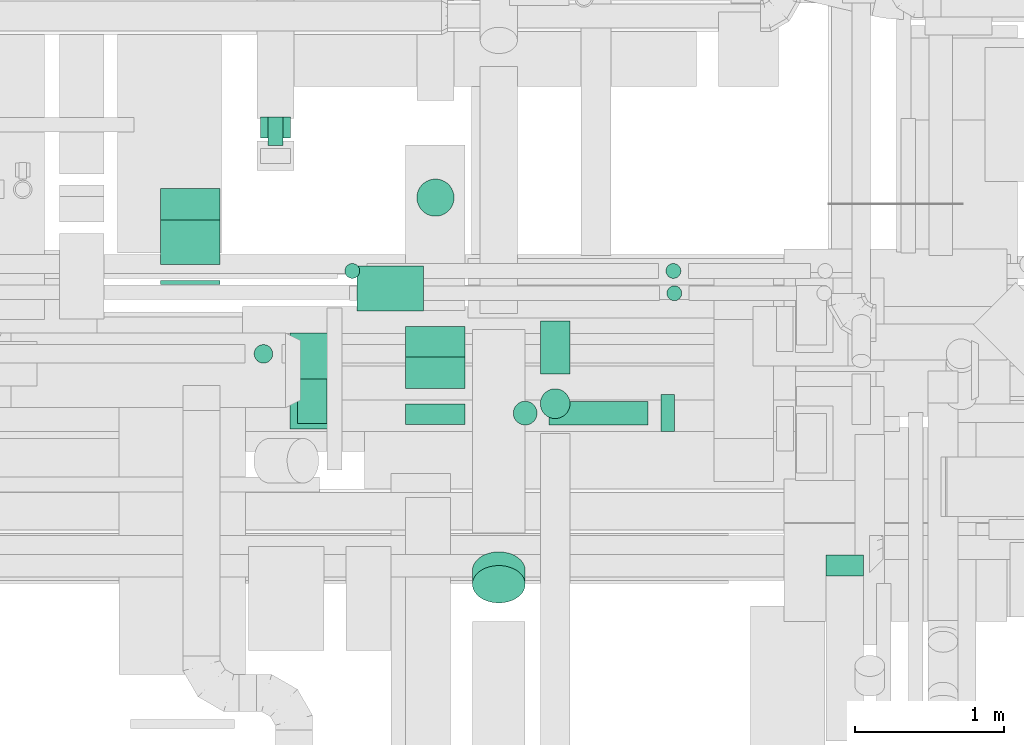
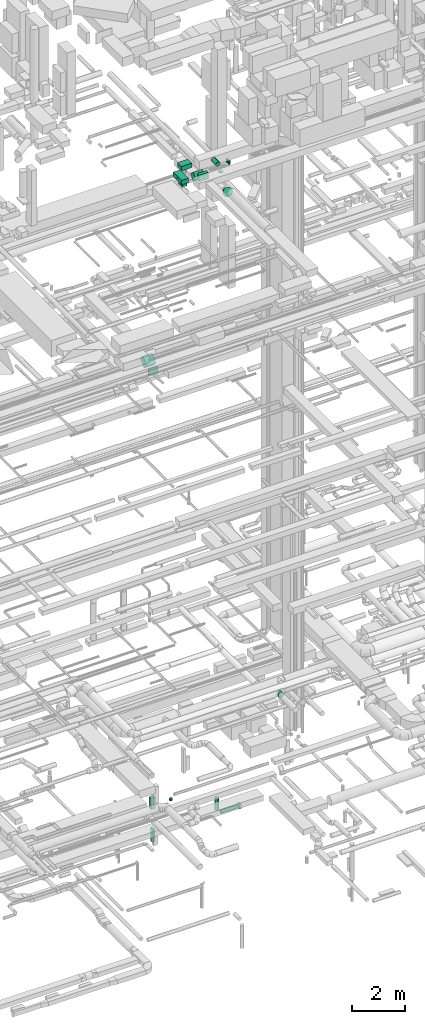
# One storey, part 170 of 337: 20 flow segments, 1 flow fitting.
"""IFC2X3 building model written with IfcOpenShell, lengths in millimetres."""

from ifc_helpers import new_model, entity, si_unit, converted_unit, derived_unit, direction, frame, frame_2d, origin, origin_2d_with_axis, place, context, subcontext, project, spatial, rectangle, circle, extrude, faceted_brep, source, transform, mapped, material, type_object, type_shapes, element, save


model = new_model("IFC2X3")

# Units and contexts
model_context = context("Model", 3, precision=0.01, world=origin(), true_north=direction((6.12303176911189e-17, 1.0)))
body_context = subcontext(model_context, "Body", "Model", "MODEL_VIEW")
ifc_project = project(units=[si_unit("LENGTHUNIT", "METRE", prefix="MILLI"), si_unit("AREAUNIT", "SQUARE_METRE"), si_unit("VOLUMEUNIT", "CUBIC_METRE"), converted_unit("PLANEANGLEUNIT", "DEGREE", entity("IfcRatioMeasure", 0.0174532925199433), si_unit("PLANEANGLEUNIT", "RADIAN"), dimensions=[0, 0, 0, 0, 0, 0, 0]), si_unit("MASSUNIT", "GRAM", prefix="KILO"), derived_unit("MASSDENSITYUNIT", [(si_unit("MASSUNIT", "GRAM", prefix="KILO"), 1), (si_unit("LENGTHUNIT", "METRE"), -3)]), derived_unit("MOMENTOFINERTIAUNIT", [(si_unit("LENGTHUNIT", "METRE"), 4)]), si_unit("TIMEUNIT", "SECOND"), si_unit("FREQUENCYUNIT", "HERTZ"), si_unit("THERMODYNAMICTEMPERATUREUNIT", "DEGREE_CELSIUS"), derived_unit("THERMALTRANSMITTANCEUNIT", [(si_unit("MASSUNIT", "GRAM", prefix="KILO"), 1), (si_unit("THERMODYNAMICTEMPERATUREUNIT", "KELVIN"), -1), (si_unit("TIMEUNIT", "SECOND"), -3)]), derived_unit("VOLUMETRICFLOWRATEUNIT", [(si_unit("LENGTHUNIT", "METRE"), 3), (si_unit("TIMEUNIT", "SECOND"), -1)]), derived_unit("MASSFLOWRATEUNIT", [(si_unit("MASSUNIT", "GRAM", prefix="KILO"), 1), (si_unit("TIMEUNIT", "SECOND"), -1)]), derived_unit("ROTATIONALFREQUENCYUNIT", [(si_unit("TIMEUNIT", "SECOND"), -1)]), si_unit("ELECTRICCURRENTUNIT", "AMPERE"), si_unit("ELECTRICVOLTAGEUNIT", "VOLT"), si_unit("POWERUNIT", "WATT"), si_unit("FORCEUNIT", "NEWTON", prefix="KILO"), si_unit("ILLUMINANCEUNIT", "LUX"), si_unit("LUMINOUSFLUXUNIT", "LUMEN"), si_unit("LUMINOUSINTENSITYUNIT", "CANDELA"), derived_unit("USERDEFINED", [(si_unit("MASSUNIT", "GRAM", prefix="KILO"), -1), (si_unit("LENGTHUNIT", "METRE"), -2), (si_unit("TIMEUNIT", "SECOND"), 3), (si_unit("LUMINOUSFLUXUNIT", "LUMEN"), 1)]), derived_unit("LINEARVELOCITYUNIT", [(si_unit("LENGTHUNIT", "METRE"), 1), (si_unit("TIMEUNIT", "SECOND"), -1)]), si_unit("PRESSUREUNIT", "PASCAL"), derived_unit("USERDEFINED", [(si_unit("LENGTHUNIT", "METRE"), -2), (si_unit("MASSUNIT", "GRAM", prefix="KILO"), 1), (si_unit("TIMEUNIT", "SECOND"), -2)]), derived_unit("LINEARFORCEUNIT", [(si_unit("MASSUNIT", "GRAM", prefix="KILO"), 1), (si_unit("LENGTHUNIT", "METRE"), 1), (si_unit("TIMEUNIT", "SECOND"), -2), (si_unit("LENGTHUNIT", "METRE"), -1)]), derived_unit("PLANARFORCEUNIT", [(si_unit("MASSUNIT", "GRAM", prefix="KILO"), 1), (si_unit("LENGTHUNIT", "METRE"), 1), (si_unit("TIMEUNIT", "SECOND"), -2), (si_unit("LENGTHUNIT", "METRE"), -2)])], contexts=[model_context])

# Site, building, storey
site_placement = place(None, origin())
site = spatial("IfcSite", under=ifc_project, at=site_placement, CompositionType="ELEMENT")
building_placement = place(site_placement, origin())
building = spatial("IfcBuilding", under=site, at=building_placement, CompositionType="ELEMENT")
storey_placement = place(building_placement, origin())
storey = spatial("IfcBuildingStorey", under=building, at=storey_placement, CompositionType="ELEMENT", Elevation=0.0)

# Flow segments
duct_segment_type_1 = type_object("IfcDuctSegmentType", PredefinedType="NOTDEFINED")
flow_segment_1_placement = place(storey_placement, frame((38971.44, 11043.03, -3600.0)))
element("IfcFlowSegment", 1, at=flow_segment_1_placement, inside=storey, type_object=duct_segment_type_1, context=body_context, shape_type="SweptSolid", body=[
    extrude(rectangle(XDim=190.000000000041, YDim=99.9999999999989, at=origin_2d_with_axis()), frame((50.0, 95.0, 0.0), z_axis=(0.0, 0.0, 1.0), x_axis=(0.0, 1.0, 0.0)), (0.0, 0.0, 1.0), 600.0),
])
flow_segment_2_placement = place(storey_placement, frame((38921.44, 11093.03, -2100.0)))
element("IfcFlowSegment", 2, at=flow_segment_2_placement, inside=storey, type_object=duct_segment_type_1, context=body_context, shape_type="SweptSolid", body=[
    extrude(rectangle(XDim=140.000000000001, YDim=200.000000000002, at=origin_2d_with_axis()), frame((100.0, 70.0, 0.0), z_axis=(0.0, 0.0, 1.0), x_axis=(0.0, 1.0, 0.0)), (0.0, 0.0, 1.0), 500.0),
])
flow_segment_3_placement = place(storey_placement, frame((38248.74, 10241.8, 18681.8)))
element("IfcFlowSegment", 3, at=flow_segment_3_placement, inside=storey, type_object=duct_segment_type_1, context=body_context, shape_type="SweptSolid", body=[
    extrude(rectangle(XDim=300.0, YDim=400.000000000004, at=frame_2d((0.0, 0.0), x_axis=(0.0, 1.0))), frame((200.0, 106.07, 106.07), z_axis=(0.0, 0.707106781186446, 0.707106781186649), x_axis=(-1.0, 0.0, 0.0)), (0.0, 0.0, 1.0), 423.223304703279),
])
flow_segment_4_placement = place(storey_placement, frame((38248.74, 10110.56, 18550.0)))
element("IfcFlowSegment", 4, at=flow_segment_4_placement, inside=storey, type_object=duct_segment_type_1, context=body_context, shape_type="SweptSolid", body=[
    extrude(rectangle(XDim=25.1713871417928, YDim=400.0, at=origin_2d_with_axis()), frame((200.0, 12.59, 0.0), z_axis=(0.0, 0.0, 1.0), x_axis=(0.0, 1.0, 0.0)), (0.0, 0.0, 1.0), 300.000000000001),
])
flow_segment_5_placement = place(storey_placement, frame((39895.11, 9169.98, 27400.0)))
element("IfcFlowSegment", 5, at=flow_segment_5_placement, inside=storey, type_object=duct_segment_type_1, context=body_context, shape_type="SweptSolid", body=[
    extrude(rectangle(XDim=135.135931288061, YDim=399.999999999996, at=origin_2d_with_axis()), frame((200.0, 67.57, 0.0), z_axis=(0.0, 0.0, 1.0), x_axis=(0.0, 1.0, 0.0)), (0.0, 0.0, 1.0), 300.000000000001),
])
flow_segment_6_placement = place(storey_placement, frame((39895.11, 9411.18, 27151.8)))
element("IfcFlowSegment", 6, at=flow_segment_6_placement, inside=storey, type_object=duct_segment_type_1, context=body_context, shape_type="SweptSolid", body=[
    extrude(rectangle(XDim=288.873016277931, YDim=300.0, at=origin_2d_with_axis()), frame((0.0, 208.2, 208.2), z_axis=(1.0, 0.0, 0.0), x_axis=(0.0, -0.707106781186546, 0.707106781186549)), (0.0, 0.0, 1.0), 399.999999999996),
])
flow_segment_7_placement = place(storey_placement, frame((39166.85, 9174.41, 27400.0)))
element("IfcFlowSegment", 7, at=flow_segment_7_placement, inside=storey, type_object=duct_segment_type_1, context=body_context, shape_type="SweptSolid", body=[
    extrude(rectangle(XDim=200.000000000007, YDim=300.0, at=origin_2d_with_axis()), frame((100.0, 150.0, 0.0)), (0.0, 0.0, 1.0), 130.000000000035),
])
flow_segment_8_placement = place(storey_placement, frame((39566.85, 9932.41, 27550.0)))
element("IfcFlowSegment", 8, at=flow_segment_8_placement, inside=storey, type_object=duct_segment_type_1, context=body_context, shape_type="SweptSolid", body=[
    extrude(rectangle(XDim=446.999999999985, YDim=300.000000000001, at=origin_2d_with_axis()), frame((223.5, 150.0, 0.0), z_axis=(0.0, 0.0, 1.0), x_axis=(-1.0, 0.0, 0.0)), (0.0, 0.0, 1.0), 199.999999999998),
])
flow_segment_9_placement = place(storey_placement, frame((39116.85, 9137.41, 27550.0)))
element("IfcFlowSegment", 9, at=flow_segment_9_placement, inside=storey, type_object=duct_segment_type_1, context=body_context, shape_type="SweptSolid", body=[
    extrude(rectangle(XDim=645.000000000006, YDim=300.000000000001, at=origin_2d_with_axis()), frame((150.0, 322.5, 0.0), z_axis=(0.0, 0.0, 1.0), x_axis=(0.0, -1.0, 0.0)), (0.0, 0.0, 1.0), 199.999999999998),
])
duct_segment_type_2 = type_object("IfcDuctSegmentType", PredefinedType="NOTDEFINED")
flow_segment_10_placement = place(storey_placement, frame((40616.08, 9163.41, -1593.0)))
element("IfcFlowSegment", 10, at=flow_segment_10_placement, inside=storey, type_object=duct_segment_type_2, context=body_context, shape_type="SweptSolid", body=[
    extrude(circle(Radius=80.0, at=origin_2d_with_axis()), frame((81.6, 81.6, 0.0), z_axis=(0.0, 0.0, 1.0), x_axis=(-1.0, 0.0, 0.0)), (0.0, 0.0, 1.0), 548.000009045239),
])
flow_segment_11_placement = place(storey_placement, frame((40857.67, 9163.41, -1834.6)))
element("IfcFlowSegment", 11, at=flow_segment_11_placement, inside=storey, type_object=duct_segment_type_2, context=body_context, shape_type="SweptSolid", body=[
    extrude(circle(Radius=80.0, at=origin_2d_with_axis()), frame((0.0, 81.6, 81.6), z_axis=(1.0, 0.0, 0.0), x_axis=(0.0, -1.0, 0.0)), (0.0, 0.0, 1.0), 663.702439249885),
])
flow_segment_12_placement = place(storey_placement, frame((41611.37, 9118.41, -1879.6)))
element("IfcFlowSegment", 12, at=flow_segment_12_placement, inside=storey, type_object=duct_segment_type_2, context=body_context, shape_type="SweptSolid", body=[
    extrude(circle(Radius=125.0, at=origin_2d_with_axis()), frame((0.0, 126.6, 126.6), z_axis=(1.0, 0.0, 0.0), x_axis=(0.0, -1.0, 0.0)), (0.0, 0.0, 1.0), 90.0000000000315),
])
flow_segment_13_placement = place(storey_placement, frame((39968.51, 10565.83, 26830.0)))
element("IfcFlowSegment", 13, at=flow_segment_13_placement, inside=storey, type_object=duct_segment_type_2, context=body_context, shape_type="SweptSolid", body=[
    extrude(circle(Radius=125.0, at=origin_2d_with_axis()), frame((126.6, 126.6, 0.0)), (0.0, 0.0, 1.0), 169.999999999987),
])
flow_segment_14_placement = place(storey_placement, frame((40797.44, 9508.41, 27548.4)))
element("IfcFlowSegment", 14, at=flow_segment_14_placement, inside=storey, type_object=duct_segment_type_2, context=body_context, shape_type="SweptSolid", body=[
    extrude(circle(Radius=100.0, at=origin_2d_with_axis()), frame((101.6, 0.0, 101.6), z_axis=(0.0, 1.0, 0.0), x_axis=(-1.0, 0.0, 0.0)), (0.0, 0.0, 1.0), 353.999999999978),
])
flow_segment_15_placement = place(storey_placement, frame((41641.63, 10148.35, 27050.0)))
element("IfcFlowSegment", 15, at=flow_segment_15_placement, inside=storey, type_object=duct_segment_type_2, context=body_context, shape_type="SweptSolid", body=[
    extrude(circle(Radius=50.0, at=origin_2d_with_axis()), frame((51.6, 51.6, 0.0), z_axis=(0.0, 0.0, 1.0), x_axis=(0.0, -1.0, 0.0)), (0.0, 0.0, 1.0), 150.000000000746),
])
flow_segment_16_placement = place(storey_placement, frame((41647.68, 9998.34, 27050.0)))
element("IfcFlowSegment", 16, at=flow_segment_16_placement, inside=storey, type_object=duct_segment_type_2, context=body_context, shape_type="SweptSolid", body=[
    extrude(circle(Radius=50.0, at=origin_2d_with_axis()), frame((51.6, 51.6, 0.0), z_axis=(0.0, 0.0, 1.0), x_axis=(0.0, 1.0, 0.0)), (0.0, 0.0, 1.0), 150.000000000009),
])
flow_segment_17_placement = place(storey_placement, frame((40797.44, 9206.81, 27440.0)))
element("IfcFlowSegment", 17, at=flow_segment_17_placement, inside=storey, type_object=duct_segment_type_2, context=body_context, shape_type="SweptSolid", body=[
    extrude(circle(Radius=100.0, at=origin_2d_with_axis()), frame((101.6, 101.6, 0.0)), (0.0, 0.0, 1.0), 9.99999999997174),
])
flow_segment_18_placement = place(storey_placement, frame((39485.21, 10148.35, 27050.0)))
element("IfcFlowSegment", 18, at=flow_segment_18_placement, inside=storey, type_object=duct_segment_type_2, context=body_context, shape_type="SweptSolid", body=[
    extrude(circle(Radius=50.0, at=origin_2d_with_axis()), frame((51.6, 51.6, 0.0), z_axis=(0.0, 0.0, 1.0), x_axis=(0.0, -1.0, 0.0)), (0.0, 0.0, 1.0), 100.000000000038),
])
flow_segment_19_placement = place(storey_placement, frame((40341.53, 7968.68, 27176.87)))
element("IfcFlowSegment", 19, at=flow_segment_19_placement, inside=storey, type_object=duct_segment_type_2, context=body_context, shape_type="SweptSolid", body=[
    extrude(circle(Radius=177.5, at=origin_2d_with_axis()), frame((179.1, 127.11, 219.15), z_axis=(0.0, 0.707106792500256, -0.707106769872839), x_axis=(1.0, 0.0, 0.0)), (0.0, 0.0, 1.0), 130.172452869869),
])
flow_segment_20_placement = place(storey_placement, frame((38875.72, 9579.05, -795.0)))
element("IfcFlowSegment", 20, at=flow_segment_20_placement, inside=storey, type_object=duct_segment_type_2, context=body_context, shape_type="SweptSolid", body=[
    extrude(circle(Radius=62.5, at=origin_2d_with_axis()), frame((64.1, 64.1, 0.0), z_axis=(0.0, 0.0, 1.0), x_axis=(0.0, 1.0, 0.0)), (0.0, 0.0, 1.0), 95.0000000000028),
])

# Flow fitting
ifc_material = material()
duct_fitting_type = type_object("IfcDuctFittingType", PredefinedType="NOTDEFINED", material=ifc_material)
shared_shape = source(origin(), body_context, "Body", "Brep", [
    faceted_brep([(20.0, 32.35, -120.74), (20.0, 62.5, -108.25), (20.0, 88.39, -88.39), (20.0, 108.25, -62.5), (20.0, 120.74, -32.35), (20.0, 125.0, 0.0), (20.0, 120.74, 32.35), (20.0, 108.25, 62.5), (20.0, 88.39, 88.39), (20.0, 62.5, 108.25), (20.0, 32.35, 120.74), (20.0, 0.0, 125.0), (20.0, -32.35, 120.74), (20.0, -62.5, 108.25), (20.0, -88.39, 88.39), (20.0, -108.25, 62.5), (20.0, -120.74, 32.35), (20.0, -125.0, 0.0), (20.0, -120.74, -32.35), (20.0, -108.25, -62.5), (20.0, -88.39, -88.39), (20.0, -62.5, -108.25), (20.0, -32.35, -120.74), (20.0, 0.0, -125.0), (0.0, 0.0, 125.0), (0.0, 32.35, 120.74), (-118.9, 32.35, 120.74), (-118.9, 0.0, 125.0), (0.0, 62.5, 108.25), (-118.9, 62.5, 108.25), (0.0, 88.39, 88.39), (-118.9, 88.39, 88.39), (0.0, 108.25, 62.5), (0.0, 120.74, 32.35), (-118.9, 120.74, 32.35), (-118.9, 108.25, 62.5), (0.0, 125.0, 0.0), (-118.9, 125.0, 0.0), (0.0, 120.74, -32.35), (-118.9, 120.74, -32.35), (0.0, 108.25, -62.5), (-118.9, 108.25, -62.5), (0.0, 88.39, -88.39), (-118.9, 88.39, -88.39), (0.0, 62.5, -108.25), (0.0, 32.35, -120.74), (-118.9, 32.35, -120.74), (-118.9, 62.5, -108.25), (0.0, 0.0, -125.0), (-118.9, 0.0, -125.0), (0.0, -32.35, -120.74), (-118.9, -32.35, -120.74), (0.0, -62.5, -108.25), (-118.9, -62.5, -108.25), (0.0, -88.39, -88.39), (-118.9, -88.39, -88.39), (0.0, -108.25, -62.5), (0.0, -120.74, -32.35), (-118.9, -120.74, -32.35), (-118.9, -108.25, -62.5), (0.0, -125.0, 0.0), (-118.9, -125.0, 0.0), (0.0, -120.74, 32.35), (-118.9, -120.74, 32.35), (0.0, -108.25, 62.5), (-118.9, -108.25, 62.5), (0.0, -88.39, 88.39), (-118.9, -88.39, 88.39), (0.0, -62.5, 108.25), (0.0, -32.35, 120.74), (-118.9, -32.35, 120.74), (-118.9, -62.5, 108.25)], [[[0, 1, 2, 3, 4, 5, 6, 7, 8, 9, 10, 11, 12, 13, 14, 15, 16, 17, 18, 19, 20, 21, 22, 23]], [[24, 11, 10, 25, 26, 27]], [[25, 10, 9, 28, 29, 26]], [[28, 9, 8, 30, 31, 29]], [[32, 7, 6, 33, 34, 35]], [[33, 6, 5, 36, 37, 34]], [[30, 8, 7, 32, 35, 31]], [[36, 5, 4, 38, 39, 37]], [[38, 4, 3, 40, 41, 39]], [[40, 3, 2, 42, 43, 41]], [[44, 1, 0, 45, 46, 47]], [[45, 0, 23, 48, 49, 46]], [[42, 2, 1, 44, 47, 43]], [[48, 23, 22, 50, 51, 49]], [[50, 22, 21, 52, 53, 51]], [[52, 21, 20, 54, 55, 53]], [[56, 19, 18, 57, 58, 59]], [[57, 18, 17, 60, 61, 58]], [[54, 20, 19, 56, 59, 55]], [[60, 17, 16, 62, 63, 61]], [[62, 16, 15, 64, 65, 63]], [[64, 15, 14, 66, 67, 65]], [[68, 13, 12, 69, 70, 71]], [[69, 12, 11, 24, 27, 70]], [[66, 14, 13, 68, 71, 67]], [[49, 51, 53, 55, 59, 58, 61, 63, 65, 67, 71, 70, 27, 26, 29, 31, 35, 34, 37, 39, 41, 43, 47, 46]]]),
])
type_shapes(duct_fitting_type, [shared_shape])
flow_fitting_placement = place(storey_placement, frame((42844.61, 8172.51, 3550.0), z_axis=(0.0, 0.0, 1.0), x_axis=(0.0, -1.0, 0.0)))
element("IfcFlowFitting", 21, at=flow_fitting_placement, inside=storey, type_object=duct_fitting_type, material=ifc_material, context=body_context, shape_type="MappedRepresentation", body=[
    mapped(shared_shape, transform((0.0, 0.0, 0.0), scale=1.0)),
])

save(model, "model.ifc")
